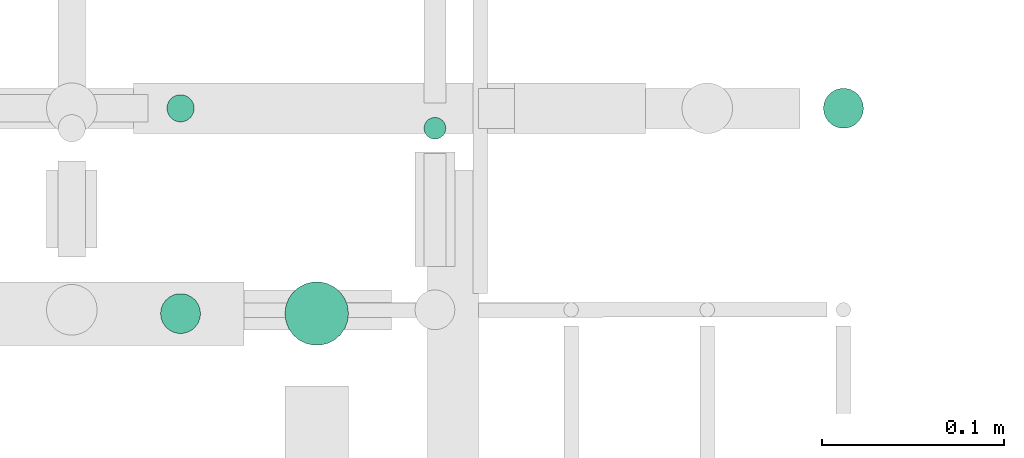
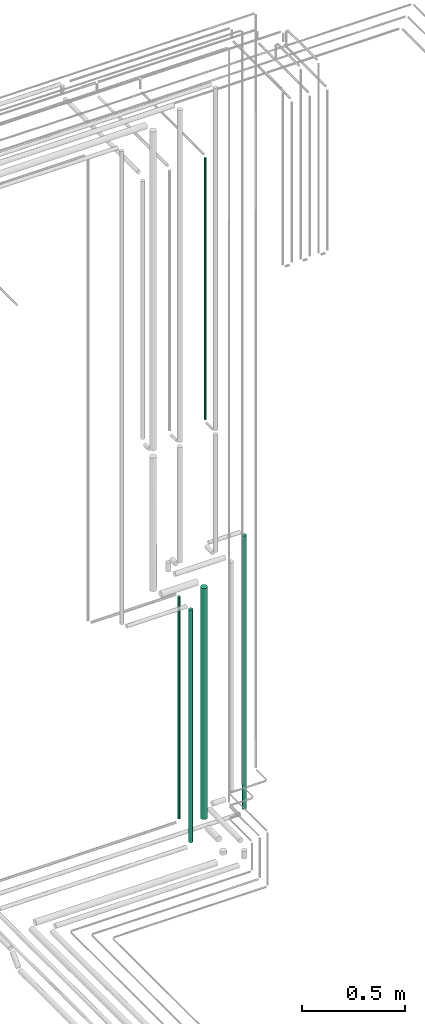
# One storey, part 101 of 331: 5 flow segments.
"""IFC2X3 building model written with IfcOpenShell, lengths in millimetres."""

from ifc_helpers import new_model, entity, si_unit, converted_unit, derived_unit, direction, frame, frame_2d, origin, origin_2d_with_axis, place, context, subcontext, project, spatial, circle, extrude, type_object, element, save


model = new_model("IFC2X3")

# Units and contexts
model_context = context("Model", 3, precision=0.01, world=origin(), true_north=direction((6.12303176911189e-17, 1.0)))
body_context = subcontext(model_context, "Body", "Model", "MODEL_VIEW")
ifc_project = project(units=[si_unit("LENGTHUNIT", "METRE", prefix="MILLI"), si_unit("AREAUNIT", "SQUARE_METRE"), si_unit("VOLUMEUNIT", "CUBIC_METRE"), converted_unit("PLANEANGLEUNIT", "DEGREE", entity("IfcRatioMeasure", 0.0174532925199433), si_unit("PLANEANGLEUNIT", "RADIAN"), dimensions=[0, 0, 0, 0, 0, 0, 0]), si_unit("MASSUNIT", "GRAM", prefix="KILO"), derived_unit("MASSDENSITYUNIT", [(si_unit("MASSUNIT", "GRAM", prefix="KILO"), 1), (si_unit("LENGTHUNIT", "METRE"), -3)]), derived_unit("MOMENTOFINERTIAUNIT", [(si_unit("LENGTHUNIT", "METRE"), 4)]), si_unit("TIMEUNIT", "SECOND"), si_unit("FREQUENCYUNIT", "HERTZ"), si_unit("THERMODYNAMICTEMPERATUREUNIT", "DEGREE_CELSIUS"), derived_unit("THERMALTRANSMITTANCEUNIT", [(si_unit("MASSUNIT", "GRAM", prefix="KILO"), 1), (si_unit("THERMODYNAMICTEMPERATUREUNIT", "KELVIN"), -1), (si_unit("TIMEUNIT", "SECOND"), -3)]), derived_unit("VOLUMETRICFLOWRATEUNIT", [(si_unit("LENGTHUNIT", "METRE"), 3), (si_unit("TIMEUNIT", "SECOND"), -1)]), derived_unit("MASSFLOWRATEUNIT", [(si_unit("MASSUNIT", "GRAM", prefix="KILO"), 1), (si_unit("TIMEUNIT", "SECOND"), -1)]), derived_unit("ROTATIONALFREQUENCYUNIT", [(si_unit("TIMEUNIT", "SECOND"), -1)]), si_unit("ELECTRICCURRENTUNIT", "AMPERE"), si_unit("ELECTRICVOLTAGEUNIT", "VOLT"), si_unit("POWERUNIT", "WATT"), si_unit("FORCEUNIT", "NEWTON", prefix="KILO"), si_unit("ILLUMINANCEUNIT", "LUX"), si_unit("LUMINOUSFLUXUNIT", "LUMEN"), si_unit("LUMINOUSINTENSITYUNIT", "CANDELA"), derived_unit("USERDEFINED", [(si_unit("MASSUNIT", "GRAM", prefix="KILO"), -1), (si_unit("LENGTHUNIT", "METRE"), -2), (si_unit("TIMEUNIT", "SECOND"), 3), (si_unit("LUMINOUSFLUXUNIT", "LUMEN"), 1)]), derived_unit("LINEARVELOCITYUNIT", [(si_unit("LENGTHUNIT", "METRE"), 1), (si_unit("TIMEUNIT", "SECOND"), -1)]), si_unit("PRESSUREUNIT", "PASCAL"), derived_unit("USERDEFINED", [(si_unit("LENGTHUNIT", "METRE"), -2), (si_unit("MASSUNIT", "GRAM", prefix="KILO"), 1), (si_unit("TIMEUNIT", "SECOND"), -2)]), derived_unit("LINEARFORCEUNIT", [(si_unit("MASSUNIT", "GRAM", prefix="KILO"), 1), (si_unit("LENGTHUNIT", "METRE"), 1), (si_unit("TIMEUNIT", "SECOND"), -2), (si_unit("LENGTHUNIT", "METRE"), -1)]), derived_unit("PLANARFORCEUNIT", [(si_unit("MASSUNIT", "GRAM", prefix="KILO"), 1), (si_unit("LENGTHUNIT", "METRE"), 1), (si_unit("TIMEUNIT", "SECOND"), -2), (si_unit("LENGTHUNIT", "METRE"), -2)])], contexts=[model_context])

# Site, building, storey
site_placement = place(None, frame((0.0, -0.00077364408347762, 0.0)))
site = spatial("IfcSite", under=ifc_project, at=site_placement, CompositionType="ELEMENT")
building_placement = place(site_placement, origin())
building = spatial("IfcBuilding", under=site, at=building_placement, CompositionType="ELEMENT")
storey_placement = place(building_placement, origin())
storey = spatial("IfcBuildingStorey", under=building, at=storey_placement, CompositionType="ELEMENT", Elevation=0.0)

# Flow segments
pipe_segment_type = type_object("IfcPipeSegmentType", PredefinedType="NOTDEFINED")
flow_segment_1_placement = place(building_placement, frame((66702.5166110417, 8242.40537015914, 5114.0)))
element("IfcFlowSegment", 1, at=flow_segment_1_placement, inside=storey, type_object=pipe_segment_type, context=body_context, shape_type="SweptSolid", body=[
    extrude(circle(Radius=6.0, at=frame_2d((0.0, -1.08286712929839e-12), x_axis=(1.0, 0.0))), frame((7.59527223591454, 7.59527223591454, 0.0), z_axis=(0.0, 0.0, 1.0), x_axis=(-1.0, 0.0, 0.0)), (0.0, 0.0, 1.0), 1546.99999999997),
])
flow_segment_2_placement = place(building_placement, frame((66557.4020544242, 8135.3349946452, 2724.0)))
element("IfcFlowSegment", 2, at=flow_segment_2_placement, inside=storey, type_object=pipe_segment_type, context=body_context, shape_type="SweptSolid", body=[
    extrude(circle(Radius=11.0, at=origin_2d_with_axis()), frame((12.5952722359134, 12.5952722359156, 0.0), z_axis=(0.0, 0.0, 1.0), x_axis=(-1.0, 0.0, 0.0)), (0.0, 0.0, 1.0), 1377.00003043302),
])
flow_segment_3_placement = place(building_placement, frame((66560.9020522448, 8251.90500989853, 2793.0)))
element("IfcFlowSegment", 3, at=flow_segment_3_placement, inside=storey, type_object=pipe_segment_type, context=body_context, shape_type="SweptSolid", body=[
    extrude(circle(Radius=7.5, at=origin_2d_with_axis()), frame((9.09527223591419, 9.09563249651603, 2.05628129776869e-06), z_axis=(0.0, -2.74170921860843e-07, 1.0), x_axis=(-1.0, 0.0, 0.0)), (0.0, 0.0, 1.0), 1314.00003043305),
])
flow_segment_4_placement = place(building_placement, frame((66625.9020544242, 8128.83499464573, 2839.99986546339)))
element("IfcFlowSegment", 4, at=flow_segment_4_placement, inside=storey, type_object=pipe_segment_type, context=body_context, shape_type="SweptSolid", body=[
    extrude(circle(Radius=17.5, at=origin_2d_with_axis()), frame((19.0952722359119, 19.0952722353976, 0.000134535065626551), z_axis=(0.0, 7.68771805624028e-06, 1.0), x_axis=(-1.0, 0.0, 0.0)), (0.0, 0.0, 1.0), 1367.79602254077),
])
flow_segment_5_placement = place(building_placement, frame((66922.5166110417, 8248.40537015914, 2724.0)))
element("IfcFlowSegment", 5, at=flow_segment_5_placement, inside=storey, type_object=pipe_segment_type, context=body_context, shape_type="SweptSolid", body=[
    extrude(circle(Radius=11.0, at=origin_2d_with_axis()), frame((12.5952722359134, 12.5952722359156, 0.0), z_axis=(0.0, 0.0, 1.0), x_axis=(-1.0, 0.0, 0.0)), (0.0, 0.0, 1.0), 1619.79602249765),
])

save(model, "model.ifc")
